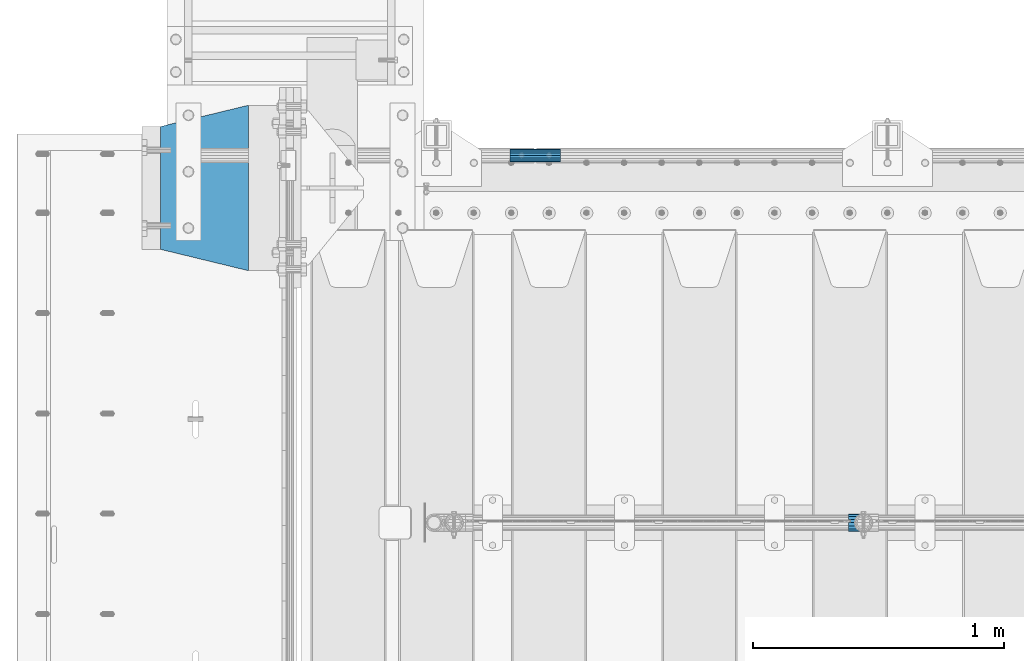
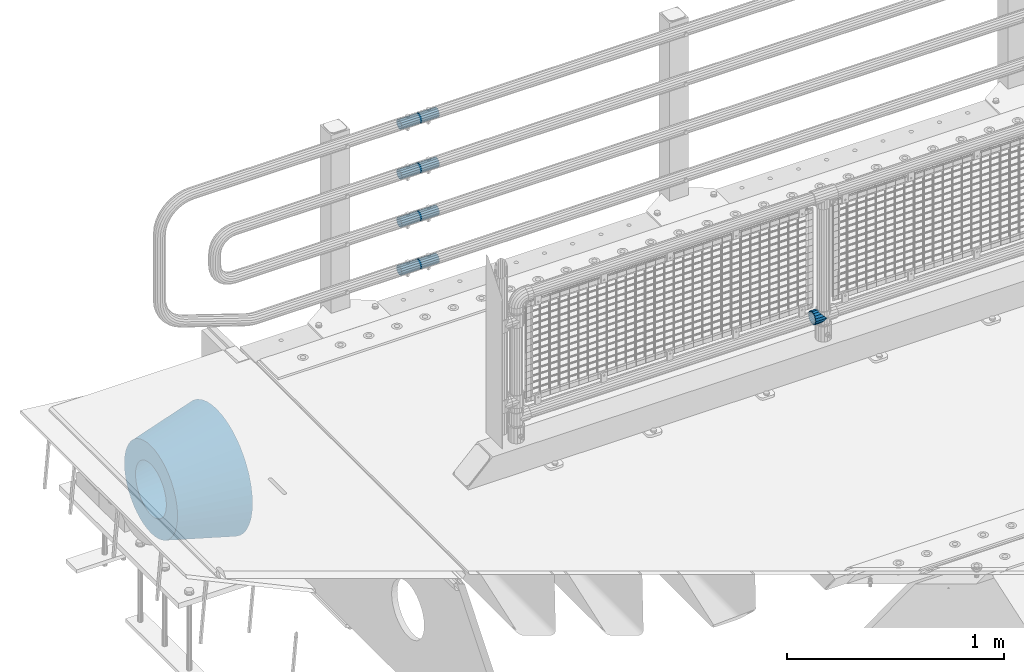
# One storey, part 162 of 270: 6 beams.
"""IFC2X3 building model written with IfcOpenShell, lengths in millimetres."""

from ifc_helpers import new_model, si_unit, frame, origin_with_axes, place, context, subcontext, project, spatial, faceted_brep, material, type_object, element, save


model = new_model("IFC2X3")

# Units and contexts
model_context = context("Model", 3, precision=1e-05, world=origin_with_axes())
body_context = subcontext(model_context, "Body", "Model", "MODEL_VIEW")
ifc_project = project(units=[si_unit("LENGTHUNIT", "METRE", prefix="MILLI"), si_unit("AREAUNIT", "SQUARE_METRE"), si_unit("VOLUMEUNIT", "CUBIC_METRE"), si_unit("MASSUNIT", "GRAM", prefix="KILO"), si_unit("TIMEUNIT", "SECOND"), si_unit("PLANEANGLEUNIT", "RADIAN"), si_unit("SOLIDANGLEUNIT", "STERADIAN"), si_unit("THERMODYNAMICTEMPERATUREUNIT", "DEGREE_CELSIUS"), si_unit("LUMINOUSINTENSITYUNIT", "LUMEN")], contexts=[model_context])

# Site, building, storey
site_placement = place(None, origin_with_axes())
site = spatial("IfcSite", under=ifc_project, at=site_placement, CompositionType="ELEMENT")
building_placement = place(site_placement, origin_with_axes())
building = spatial("IfcBuilding", under=site, at=building_placement, Name="Standard", CompositionType="ELEMENT")
storey_placement = place(building_placement, origin_with_axes())
storey = spatial("IfcBuildingStorey", under=building, at=storey_placement, Name="Undefined", CompositionType="ELEMENT", Elevation=0.0)

# Beams
ifc_material_1 = material(Name="Misc_Undefined")
beam_type_1 = type_object("IfcBeamType", PredefinedType="NOTDEFINED")
beam_1_placement = place(storey_placement, frame((2193.85, -16335.5, 298.17), z_axis=(0.0, 1.0, 0.0), x_axis=(1.0, 0.0, 0.0)))
element("IfcBeam", 1, at=beam_1_placement, inside=storey, type_object=beam_type_1, material=ifc_material_1, context=body_context, shape_type="Brep", body=[
    faceted_brep([(60.1499999999978, 0.0, -35.1499999999996), (46.698677352364, 13.4513226476329, -32.4743655677721), (46.698677352364, -13.4513226476329, -32.4743655677721), (33.0273231408937, 21.4606908090117, 21.4606908090118), (27.6756344322275, 26.8123795176776, 13.4513226476338), (27.6756344322275, 32.4743655677717, 13.4513226476338), (35.2951966412911, 24.8548033587072, 24.8548033587067), (35.2951966412911, 16.3810424080045, 24.8548033587067), (27.310256188277, 28.0397438117175, 11.6144421722802), (24.9999999999964, 30.35, 0.0), (24.9999999999964, 35.15, 0.0), (27.6756344322275, 26.8123795176775, -13.4513226476338), (27.6756344322275, 32.4743655677717, -13.4513226476338), (27.310256188277, 28.0397438117175, -11.6144421722802), (35.2951966412911, 16.3810424080045, -24.8548033587067), (35.2951966412911, 24.8548033587072, -24.8548033587067), (33.0273231408937, 21.4606908090117, -21.4606908090118), (40.0617968770166, 11.6144421722805, -28.0397438117179), (43.519339601633, 0.0, -30.3500000000004), (40.0617968770166, -11.6144421722805, -28.0397438117179), (35.2951966412911, -16.3810424080045, -24.8548033587067), (35.2951966412911, -24.8548033587072, -24.8548033587067), (33.0273231408937, -21.4606908090117, -21.4606908090118), (27.6756344322275, -26.8123795176776, -13.4513226476338), (27.6756344322275, -32.4743655677717, -13.4513226476338), (27.310256188277, -28.0397438117175, -11.6144421722802), (24.9999999999964, -30.35, 0.0), (24.9999999999964, -35.15, 0.0), (27.310256188277, -28.0397438117175, 11.6144421722802), (27.6756344322275, -26.8123795176775, 13.4513226476338), (27.6756344322275, -32.4743655677717, 13.4513226476338), (33.0273231408937, -21.4606908090117, 21.4606908090118), (35.2951966412911, -16.3810424080078, 24.8548033587067), (35.2951966412911, -24.8548033587072, 24.8548033587067), (60.1499999999978, 0.0, 35.1499999999996), (46.698677352364, -13.4513226476329, 32.4743655677721), (46.698677352364, 13.4513226476329, 32.4743655677721), (40.061796877013, -11.6144421722805, 28.0397438117179), (43.5193396016293, 0.0, 30.3500000000004), (40.061796877013, 11.6144421722805, 28.0397438117179), (0.0, -32.4743655677721, -13.4513226476338), (0.0, -24.8548033587067, -24.8548033587067), (0.0, -13.4513226476338, -32.4743655677703), (0.0, 0.0, -35.1499999999996), (0.0, 13.4513226476338, -32.4743655677703), (0.0, 24.8548033587067, -24.8548033587067), (0.0, 32.4743655677721, -13.4513226476338), (0.0, 35.1499999999996, 0.0), (0.0, 32.4743655677721, 13.4513226476338), (0.0, 24.8548033587067, 24.8548033587067), (0.0, 13.4513226476338, 32.4743655677703), (0.0, 0.0, 35.1499999999996), (0.0, -32.4743655677721, 13.4513226476338), (0.0, -35.1499999999996, 0.0), (0.0, -24.8548033587067, 24.8548033587067), (0.0, -13.4513226476338, 32.4743655677703), (0.0, -28.0397438117179, -11.614442172282), (0.0, -21.4606908090118, -21.46069080901), (0.0, -11.6144421722802, -28.0397438117179), (0.0, 0.0, -30.3499999999985), (0.0, 11.6144421722802, -28.0397438117179), (0.0, 21.4606908090118, -21.46069080901), (0.0, 28.0397438117179, -11.614442172282), (0.0, 30.3500000000004, 0.0), (0.0, 28.0397438117179, 11.614442172282), (0.0, 21.4606908090118, 21.46069080901), (0.0, 11.6144421722802, 28.0397438117179), (0.0, 0.0, 30.3499999999985), (0.0, -11.6144421722802, 28.0397438117179), (0.0, -21.4606908090118, 21.46069080901), (0.0, -28.0397438117179, 11.614442172282), (0.0, -30.3500000000004, 0.0)], [[[0, 1, 2]], [[3, 4, 5, 6, 7]], [[8, 9, 10, 5, 4]], [[11, 12, 10, 9, 13]], [[14, 15, 12, 11, 16]], [[2, 1, 15, 14, 17, 18, 19, 20, 21]], [[21, 20, 22, 23, 24]], [[24, 23, 25, 26, 27]], [[27, 26, 28, 29, 30]], [[30, 29, 31, 32, 33]], [[34, 35, 36]], [[33, 32, 37, 38, 39, 7, 6, 36, 35]], [[40, 41, 21, 24]], [[41, 42, 2, 21]], [[42, 43, 0, 2]], [[43, 44, 1, 0]], [[44, 45, 15, 1]], [[45, 46, 12, 15]], [[46, 47, 10, 12]], [[47, 48, 5, 10]], [[48, 49, 6, 5]], [[49, 50, 36, 6]], [[50, 51, 34, 36]], [[52, 53, 27, 30]], [[54, 52, 30, 33]], [[55, 54, 33, 35]], [[51, 55, 35, 34]], [[53, 40, 24, 27]], [[52, 54, 55, 51, 50, 49, 48, 47, 46, 45, 44, 43, 42, 41, 40, 53], [56, 57, 58, 59, 60, 61, 62, 63, 64, 65, 66, 67, 68, 69, 70, 71]], [[68, 67, 38, 37]], [[31, 69, 68, 37, 32]], [[28, 70, 69, 31, 29]], [[71, 70, 28, 26]], [[56, 71, 26, 25]], [[57, 56, 25, 23, 22]], [[58, 57, 22, 20, 19]], [[59, 58, 19, 18]], [[60, 59, 18, 17]], [[16, 61, 60, 17, 14]], [[13, 62, 61, 16, 11]], [[63, 62, 13, 9]], [[64, 63, 9, 8]], [[65, 64, 8, 4, 3]], [[66, 65, 3, 7, 39]], [[67, 66, 39, 38]]]),
])
ifc_material_2 = material()
beam_type_2 = type_object("IfcBeamType", PredefinedType="NOTDEFINED")
beam_2_placement = place(storey_placement, frame((844.997502999948, -14870.1499999996, 149.849999999726), z_axis=(0.0, 0.0, 1.0), x_axis=(1.0, 0.0, 0.0)))
element("IfcBeam", 2, at=beam_2_placement, inside=storey, type_object=beam_type_2, material=ifc_material_2, context=body_context, shape_type="Brep", body=[
    faceted_brep([(0.0, -21.8999999999996, 0.0), (0.0, -20.232961761998, 8.38076716879547), (200.0, -20.232961761998, 8.38076716879547), (200.0, -21.8999999999996, 0.0), (0.0, -15.4856385079856, 15.4856385079854), (200.0, -15.4856385079856, 15.4856385079854), (0.0, -8.3807671687955, 20.2329617619972), (200.0, -8.3807671687955, 20.2329617619972), (0.0, 0.0, 21.9), (200.0, 0.0, 21.9), (0.0, 8.3807671687955, 20.2329617619972), (200.0, 8.3807671687955, 20.2329617619972), (0.0, 15.4856385079856, 15.4856385079854), (200.0, 15.4856385079856, 15.4856385079854), (0.0, 20.232961761998, 8.38076716879547), (200.0, 20.232961761998, 8.38076716879547), (0.0, 21.8999999999996, 0.0), (200.0, 21.8999999999996, 0.0), (0.0, 20.232961761998, -8.38076716879547), (200.0, 20.232961761998, -8.38076716879547), (0.0, 15.4856385079856, -15.4856385079854), (200.0, 15.4856385079856, -15.4856385079854), (0.0, 8.3807671687955, -20.2329617619972), (200.0, 8.3807671687955, -20.2329617619972), (0.0, 0.0, -21.9), (200.0, 0.0, -21.9), (0.0, -8.3807671687955, -20.2329617619972), (200.0, -8.3807671687955, -20.2329617619972), (0.0, -15.4856385079856, -15.4856385079854), (200.0, -15.4856385079856, -15.4856385079854), (0.0, -20.232961761998, -8.38076716879547), (200.0, -20.232961761998, -8.38076716879547), (0.0, -25.5, 0.0), (0.0, -23.5589280790373, -9.7584275253098), (200.0, -23.5589280790373, -9.7584275253098), (200.0, -25.5, 0.0), (0.0, -18.0312229202573, -18.031222920257), (200.0, -18.0312229202573, -18.031222920257), (0.0, -9.75842752531025, -23.5589280790378), (200.0, -9.75842752531025, -23.5589280790378), (0.0, 0.0, -25.5), (200.0, 0.0, -25.5), (0.0, 9.75842752531025, -23.5589280790378), (200.0, 9.75842752531025, -23.5589280790378), (0.0, 18.0312229202573, -18.031222920257), (200.0, 18.0312229202573, -18.031222920257), (0.0, 23.5589280790373, -9.7584275253098), (200.0, 23.5589280790373, -9.7584275253098), (0.0, 25.5, 0.0), (200.0, 25.5, 0.0), (0.0, 23.5589280790373, 9.7584275253098), (200.0, 23.5589280790373, 9.7584275253098), (0.0, 18.0312229202573, 18.031222920257), (200.0, 18.0312229202573, 18.031222920257), (0.0, 9.75842752531025, 23.5589280790378), (200.0, 9.75842752531025, 23.5589280790378), (0.0, 0.0, 25.5), (200.0, 0.0, 25.5), (0.0, -9.75842752531025, 23.5589280790378), (200.0, -9.75842752531025, 23.5589280790378), (0.0, -18.0312229202573, 18.031222920257), (200.0, -18.0312229202573, 18.031222920257), (0.0, -23.5589280790373, 9.7584275253098), (200.0, -23.5589280790373, 9.7584275253098)], [[[0, 1, 2, 3]], [[1, 4, 5, 2]], [[4, 6, 7, 5]], [[6, 8, 9, 7]], [[8, 10, 11, 9]], [[10, 12, 13, 11]], [[12, 14, 15, 13]], [[14, 16, 17, 15]], [[16, 18, 19, 17]], [[18, 20, 21, 19]], [[20, 22, 23, 21]], [[22, 24, 25, 23]], [[24, 26, 27, 25]], [[26, 28, 29, 27]], [[28, 30, 31, 29]], [[30, 0, 3, 31]], [[32, 33, 34, 35]], [[33, 36, 37, 34]], [[36, 38, 39, 37]], [[38, 40, 41, 39]], [[40, 42, 43, 41]], [[42, 44, 45, 43]], [[44, 46, 47, 45]], [[46, 48, 49, 47]], [[48, 50, 51, 49]], [[50, 52, 53, 51]], [[52, 54, 55, 53]], [[54, 56, 57, 55]], [[56, 58, 59, 57]], [[58, 60, 61, 59]], [[60, 62, 63, 61]], [[62, 32, 35, 63]], [[37, 39, 41, 43, 45, 47, 49, 51, 53, 55, 57, 59, 61, 63, 35, 34], [5, 7, 9, 11, 13, 15, 17, 19, 21, 23, 25, 27, 29, 31, 3, 2]], [[62, 60, 58, 56, 54, 52, 50, 48, 46, 44, 42, 40, 38, 36, 33, 32], [30, 28, 26, 24, 22, 20, 18, 16, 14, 12, 10, 8, 6, 4, 1, 0]]]),
])
beam_3_placement = place(storey_placement, frame((844.997502999948, -14870.1499999996, 420.149999999725), z_axis=(0.0, 0.0, 1.0), x_axis=(1.0, 0.0, 0.0)))
element("IfcBeam", 3, at=beam_3_placement, inside=storey, type_object=beam_type_2, material=ifc_material_2, context=body_context, shape_type="Brep", body=[
    faceted_brep([(0.0, -21.8999999999996, 0.0), (0.0, -20.232961761998, 8.38076716879547), (200.0, -20.232961761998, 8.38076716879547), (200.0, -21.8999999999996, 0.0), (0.0, -15.4856385079856, 15.4856385079854), (200.0, -15.4856385079856, 15.4856385079854), (0.0, -8.3807671687955, 20.2329617619972), (200.0, -8.3807671687955, 20.2329617619972), (0.0, 0.0, 21.9), (200.0, 0.0, 21.9), (0.0, 8.3807671687955, 20.2329617619972), (200.0, 8.3807671687955, 20.2329617619972), (0.0, 15.4856385079856, 15.4856385079854), (200.0, 15.4856385079856, 15.4856385079854), (0.0, 20.232961761998, 8.38076716879547), (200.0, 20.232961761998, 8.38076716879547), (0.0, 21.8999999999996, 0.0), (200.0, 21.8999999999996, 0.0), (0.0, 20.232961761998, -8.38076716879547), (200.0, 20.232961761998, -8.38076716879547), (0.0, 15.4856385079856, -15.4856385079854), (200.0, 15.4856385079856, -15.4856385079854), (0.0, 8.3807671687955, -20.2329617619972), (200.0, 8.3807671687955, -20.2329617619972), (0.0, 0.0, -21.9), (200.0, 0.0, -21.9), (0.0, -8.3807671687955, -20.2329617619972), (200.0, -8.3807671687955, -20.2329617619972), (0.0, -15.4856385079856, -15.4856385079854), (200.0, -15.4856385079856, -15.4856385079854), (0.0, -20.232961761998, -8.38076716879547), (200.0, -20.232961761998, -8.38076716879547), (0.0, -25.5, 0.0), (0.0, -23.5589280790373, -9.7584275253098), (200.0, -23.5589280790373, -9.7584275253098), (200.0, -25.5, 0.0), (0.0, -18.0312229202573, -18.031222920257), (200.0, -18.0312229202573, -18.031222920257), (0.0, -9.75842752531025, -23.5589280790378), (200.0, -9.75842752531025, -23.5589280790378), (0.0, 0.0, -25.5), (200.0, 0.0, -25.5), (0.0, 9.75842752531025, -23.5589280790378), (200.0, 9.75842752531025, -23.5589280790378), (0.0, 18.0312229202573, -18.031222920257), (200.0, 18.0312229202573, -18.031222920257), (0.0, 23.5589280790373, -9.7584275253098), (200.0, 23.5589280790373, -9.7584275253098), (0.0, 25.5, 0.0), (200.0, 25.5, 0.0), (0.0, 23.5589280790373, 9.7584275253098), (200.0, 23.5589280790373, 9.7584275253098), (0.0, 18.0312229202573, 18.031222920257), (200.0, 18.0312229202573, 18.031222920257), (0.0, 9.75842752531025, 23.5589280790378), (200.0, 9.75842752531025, 23.5589280790378), (0.0, 0.0, 25.5), (200.0, 0.0, 25.5), (0.0, -9.75842752531025, 23.5589280790378), (200.0, -9.75842752531025, 23.5589280790378), (0.0, -18.0312229202573, 18.031222920257), (200.0, -18.0312229202573, 18.031222920257), (0.0, -23.5589280790373, 9.7584275253098), (200.0, -23.5589280790373, 9.7584275253098)], [[[0, 1, 2, 3]], [[1, 4, 5, 2]], [[4, 6, 7, 5]], [[6, 8, 9, 7]], [[8, 10, 11, 9]], [[10, 12, 13, 11]], [[12, 14, 15, 13]], [[14, 16, 17, 15]], [[16, 18, 19, 17]], [[18, 20, 21, 19]], [[20, 22, 23, 21]], [[22, 24, 25, 23]], [[24, 26, 27, 25]], [[26, 28, 29, 27]], [[28, 30, 31, 29]], [[30, 0, 3, 31]], [[32, 33, 34, 35]], [[33, 36, 37, 34]], [[36, 38, 39, 37]], [[38, 40, 41, 39]], [[40, 42, 43, 41]], [[42, 44, 45, 43]], [[44, 46, 47, 45]], [[46, 48, 49, 47]], [[48, 50, 51, 49]], [[50, 52, 53, 51]], [[52, 54, 55, 53]], [[54, 56, 57, 55]], [[56, 58, 59, 57]], [[58, 60, 61, 59]], [[60, 62, 63, 61]], [[62, 32, 35, 63]], [[37, 39, 41, 43, 45, 47, 49, 51, 53, 55, 57, 59, 61, 63, 35, 34], [5, 7, 9, 11, 13, 15, 17, 19, 21, 23, 25, 27, 29, 31, 3, 2]], [[62, 60, 58, 56, 54, 52, 50, 48, 46, 44, 42, 40, 38, 36, 33, 32], [30, 28, 26, 24, 22, 20, 18, 16, 14, 12, 10, 8, 6, 4, 1, 0]]]),
])
beam_4_placement = place(storey_placement, frame((844.997502999948, -14870.1499999996, 969.849999999726), z_axis=(0.0, 0.0, 1.0), x_axis=(1.0, 0.0, 0.0)))
element("IfcBeam", 4, at=beam_4_placement, inside=storey, type_object=beam_type_2, material=ifc_material_2, context=body_context, shape_type="Brep", body=[
    faceted_brep([(0.0, -21.8999999999996, 0.0), (0.0, -20.232961761998, 8.38076716879547), (200.0, -20.232961761998, 8.38076716879547), (200.0, -21.8999999999996, 0.0), (0.0, -15.4856385079856, 15.4856385079854), (200.0, -15.4856385079856, 15.4856385079854), (0.0, -8.3807671687955, 20.2329617619972), (200.0, -8.3807671687955, 20.2329617619972), (0.0, 0.0, 21.9), (200.0, 0.0, 21.9), (0.0, 8.3807671687955, 20.2329617619972), (200.0, 8.3807671687955, 20.2329617619972), (0.0, 15.4856385079856, 15.4856385079854), (200.0, 15.4856385079856, 15.4856385079854), (0.0, 20.232961761998, 8.38076716879547), (200.0, 20.232961761998, 8.38076716879547), (0.0, 21.8999999999996, 0.0), (200.0, 21.8999999999996, 0.0), (0.0, 20.232961761998, -8.38076716879547), (200.0, 20.232961761998, -8.38076716879547), (0.0, 15.4856385079856, -15.4856385079854), (200.0, 15.4856385079856, -15.4856385079854), (0.0, 8.3807671687955, -20.2329617619972), (200.0, 8.3807671687955, -20.2329617619972), (0.0, 0.0, -21.9), (200.0, 0.0, -21.9), (0.0, -8.3807671687955, -20.2329617619972), (200.0, -8.3807671687955, -20.2329617619972), (0.0, -15.4856385079856, -15.4856385079854), (200.0, -15.4856385079856, -15.4856385079854), (0.0, -20.232961761998, -8.38076716879547), (200.0, -20.232961761998, -8.38076716879547), (0.0, -25.5, 0.0), (0.0, -23.5589280790373, -9.7584275253098), (200.0, -23.5589280790373, -9.7584275253098), (200.0, -25.5, 0.0), (0.0, -18.0312229202573, -18.031222920257), (200.0, -18.0312229202573, -18.031222920257), (0.0, -9.75842752531025, -23.5589280790378), (200.0, -9.75842752531025, -23.5589280790378), (0.0, 0.0, -25.5), (200.0, 0.0, -25.5), (0.0, 9.75842752531025, -23.5589280790378), (200.0, 9.75842752531025, -23.5589280790378), (0.0, 18.0312229202573, -18.031222920257), (200.0, 18.0312229202573, -18.031222920257), (0.0, 23.5589280790373, -9.7584275253098), (200.0, 23.5589280790373, -9.7584275253098), (0.0, 25.5, 0.0), (200.0, 25.5, 0.0), (0.0, 23.5589280790373, 9.7584275253098), (200.0, 23.5589280790373, 9.7584275253098), (0.0, 18.0312229202573, 18.031222920257), (200.0, 18.0312229202573, 18.031222920257), (0.0, 9.75842752531025, 23.5589280790378), (200.0, 9.75842752531025, 23.5589280790378), (0.0, 0.0, 25.5), (200.0, 0.0, 25.5), (0.0, -9.75842752531025, 23.5589280790378), (200.0, -9.75842752531025, 23.5589280790378), (0.0, -18.0312229202573, 18.031222920257), (200.0, -18.0312229202573, 18.031222920257), (0.0, -23.5589280790373, 9.7584275253098), (200.0, -23.5589280790373, 9.7584275253098)], [[[0, 1, 2, 3]], [[1, 4, 5, 2]], [[4, 6, 7, 5]], [[6, 8, 9, 7]], [[8, 10, 11, 9]], [[10, 12, 13, 11]], [[12, 14, 15, 13]], [[14, 16, 17, 15]], [[16, 18, 19, 17]], [[18, 20, 21, 19]], [[20, 22, 23, 21]], [[22, 24, 25, 23]], [[24, 26, 27, 25]], [[26, 28, 29, 27]], [[28, 30, 31, 29]], [[30, 0, 3, 31]], [[32, 33, 34, 35]], [[33, 36, 37, 34]], [[36, 38, 39, 37]], [[38, 40, 41, 39]], [[40, 42, 43, 41]], [[42, 44, 45, 43]], [[44, 46, 47, 45]], [[46, 48, 49, 47]], [[48, 50, 51, 49]], [[50, 52, 53, 51]], [[52, 54, 55, 53]], [[54, 56, 57, 55]], [[56, 58, 59, 57]], [[58, 60, 61, 59]], [[60, 62, 63, 61]], [[62, 32, 35, 63]], [[37, 39, 41, 43, 45, 47, 49, 51, 53, 55, 57, 59, 61, 63, 35, 34], [5, 7, 9, 11, 13, 15, 17, 19, 21, 23, 25, 27, 29, 31, 3, 2]], [[62, 60, 58, 56, 54, 52, 50, 48, 46, 44, 42, 40, 38, 36, 33, 32], [30, 28, 26, 24, 22, 20, 18, 16, 14, 12, 10, 8, 6, 4, 1, 0]]]),
])
beam_5_placement = place(storey_placement, frame((844.997502999948, -14870.1499999996, 689.849999999726), z_axis=(0.0, 0.0, 1.0), x_axis=(1.0, 0.0, 0.0)))
element("IfcBeam", 5, at=beam_5_placement, inside=storey, type_object=beam_type_2, material=ifc_material_2, context=body_context, shape_type="Brep", body=[
    faceted_brep([(0.0, -21.8999999999996, 0.0), (0.0, -20.232961761998, 8.38076716879547), (200.0, -20.232961761998, 8.38076716879547), (200.0, -21.8999999999996, 0.0), (0.0, -15.4856385079856, 15.4856385079854), (200.0, -15.4856385079856, 15.4856385079854), (0.0, -8.3807671687955, 20.2329617619972), (200.0, -8.3807671687955, 20.2329617619972), (0.0, 0.0, 21.9), (200.0, 0.0, 21.9), (0.0, 8.3807671687955, 20.2329617619972), (200.0, 8.3807671687955, 20.2329617619972), (0.0, 15.4856385079856, 15.4856385079854), (200.0, 15.4856385079856, 15.4856385079854), (0.0, 20.232961761998, 8.38076716879547), (200.0, 20.232961761998, 8.38076716879547), (0.0, 21.8999999999996, 0.0), (200.0, 21.8999999999996, 0.0), (0.0, 20.232961761998, -8.38076716879547), (200.0, 20.232961761998, -8.38076716879547), (0.0, 15.4856385079856, -15.4856385079854), (200.0, 15.4856385079856, -15.4856385079854), (0.0, 8.3807671687955, -20.2329617619972), (200.0, 8.3807671687955, -20.2329617619972), (0.0, 0.0, -21.9), (200.0, 0.0, -21.9), (0.0, -8.3807671687955, -20.2329617619972), (200.0, -8.3807671687955, -20.2329617619972), (0.0, -15.4856385079856, -15.4856385079854), (200.0, -15.4856385079856, -15.4856385079854), (0.0, -20.232961761998, -8.38076716879547), (200.0, -20.232961761998, -8.38076716879547), (0.0, -25.5, 0.0), (0.0, -23.5589280790373, -9.7584275253098), (200.0, -23.5589280790373, -9.7584275253098), (200.0, -25.5, 0.0), (0.0, -18.0312229202573, -18.031222920257), (200.0, -18.0312229202573, -18.031222920257), (0.0, -9.75842752531025, -23.5589280790378), (200.0, -9.75842752531025, -23.5589280790378), (0.0, 0.0, -25.5), (200.0, 0.0, -25.5), (0.0, 9.75842752531025, -23.5589280790378), (200.0, 9.75842752531025, -23.5589280790378), (0.0, 18.0312229202573, -18.031222920257), (200.0, 18.0312229202573, -18.031222920257), (0.0, 23.5589280790373, -9.7584275253098), (200.0, 23.5589280790373, -9.7584275253098), (0.0, 25.5, 0.0), (200.0, 25.5, 0.0), (0.0, 23.5589280790373, 9.7584275253098), (200.0, 23.5589280790373, 9.7584275253098), (0.0, 18.0312229202573, 18.031222920257), (200.0, 18.0312229202573, 18.031222920257), (0.0, 9.75842752531025, 23.5589280790378), (200.0, 9.75842752531025, 23.5589280790378), (0.0, 0.0, 25.5), (200.0, 0.0, 25.5), (0.0, -9.75842752531025, 23.5589280790378), (200.0, -9.75842752531025, 23.5589280790378), (0.0, -18.0312229202573, 18.031222920257), (200.0, -18.0312229202573, 18.031222920257), (0.0, -23.5589280790373, 9.7584275253098), (200.0, -23.5589280790373, 9.7584275253098)], [[[0, 1, 2, 3]], [[1, 4, 5, 2]], [[4, 6, 7, 5]], [[6, 8, 9, 7]], [[8, 10, 11, 9]], [[10, 12, 13, 11]], [[12, 14, 15, 13]], [[14, 16, 17, 15]], [[16, 18, 19, 17]], [[18, 20, 21, 19]], [[20, 22, 23, 21]], [[22, 24, 25, 23]], [[24, 26, 27, 25]], [[26, 28, 29, 27]], [[28, 30, 31, 29]], [[30, 0, 3, 31]], [[32, 33, 34, 35]], [[33, 36, 37, 34]], [[36, 38, 39, 37]], [[38, 40, 41, 39]], [[40, 42, 43, 41]], [[42, 44, 45, 43]], [[44, 46, 47, 45]], [[46, 48, 49, 47]], [[48, 50, 51, 49]], [[50, 52, 53, 51]], [[52, 54, 55, 53]], [[54, 56, 57, 55]], [[56, 58, 59, 57]], [[58, 60, 61, 59]], [[60, 62, 63, 61]], [[62, 32, 35, 63]], [[37, 39, 41, 43, 45, 47, 49, 51, 53, 55, 57, 59, 61, 63, 35, 34], [5, 7, 9, 11, 13, 15, 17, 19, 21, 23, 25, 27, 29, 31, 3, 2]], [[62, 60, 58, 56, 54, 52, 50, 48, 46, 44, 42, 40, 38, 36, 33, 32], [30, 28, 26, 24, 22, 20, 18, 16, 14, 12, 10, 8, 6, 4, 1, 0]]]),
])
ifc_material_3 = material(Name="SCN-500-E2")
beam_type_3 = type_object("IfcBeamType", PredefinedType="NOTDEFINED")
beam_6_placement = place(storey_placement, frame((-199.999999999991, -15000.0, -515.0), z_axis=(0.0, 0.0, 1.0), x_axis=(-1.0, 0.0, 0.0)))
element("IfcBeam", 6, at=beam_6_placement, inside=storey, type_object=beam_type_3, material=ifc_material_3, context=body_context, shape_type="Brep", body=[
    faceted_brep([(0.0, -330.0, 0.0), (0.0, -326.641075820708, -46.9638966301842), (350.0, -242.506253260828, -34.8671353769549), (350.0, -245.0, 0.0), (0.0, -316.632681292784, -92.9717437576718), (350.0, -235.075778535553, -69.0244764261503), (0.0, -300.178558466991, -137.086954290623), (350.0, -222.859838861858, -101.776678185462), (0.0, -277.613665834289, -178.411469760347), (350.0, -206.10711554364, -132.457000276621), (0.0, -249.397359536906, -216.104042201944), (350.0, -185.158645716794, -160.440879816595), (0.0, -216.104042201943, -249.397359536905), (350.0, -160.440879816595, -185.158645716793), (0.0, -178.411469760347, -277.61366583429), (350.0, -132.457000276621, -206.107115543639), (0.0, -137.086954290622, -300.178558466991), (350.0, -101.776678185463, -222.859838861857), (0.0, -92.971743757671, -316.632681292784), (350.0, -69.0244764261497, -235.075778535552), (0.0, -46.9638966301845, -326.641075820708), (350.0, -34.867135376955, -242.506253260829), (0.0, 0.0, -330.0), (350.0, 0.0, -245.0), (0.0, 46.9638966301845, -326.641075820708), (350.0, 34.867135376955, -242.506253260829), (0.0, 92.971743757671, -316.632681292784), (350.0, 69.0244764261497, -235.075778535552), (0.0, 137.086954290622, -300.178558466991), (350.0, 101.776678185463, -222.859838861857), (0.0, 178.411469760347, -277.61366583429), (350.0, 132.457000276621, -206.107115543639), (0.0, 216.104042201943, -249.397359536905), (350.0, 160.440879816595, -185.158645716793), (0.0, 249.397359536906, -216.104042201944), (350.0, 185.158645716794, -160.440879816595), (0.0, 277.613665834289, -178.411469760347), (350.0, 206.10711554364, -132.457000276621), (0.0, 300.178558466991, -137.086954290623), (350.0, 222.859838861858, -101.776678185462), (0.0, 316.632681292784, -92.9717437576717), (350.0, 235.075778535553, -69.0244764261502), (0.0, 326.641075820708, -46.9638966301841), (350.0, 242.506253260828, -34.8671353769548), (0.0, 330.0, 0.0), (350.0, 245.0, 0.0), (0.0, 326.641075820708, 46.9638966301841), (350.0, 242.506253260828, 34.8671353769549), (0.0, 316.632681292784, 92.9717437576718), (350.0, 235.075778535553, 69.0244764261503), (0.0, 300.178558466991, 137.086954290622), (350.0, 222.859838861858, 101.776678185462), (0.0, 277.613665834289, 178.411469760347), (350.0, 206.10711554364, 132.457000276621), (0.0, 249.397359536904, 216.104042201944), (350.0, 185.158645716794, 160.440879816595), (0.0, 216.104042201943, 249.397359536905), (350.0, 160.440879816595, 185.158645716793), (0.0, 178.411469760347, 277.61366583429), (350.0, 132.457000276621, 206.107115543639), (0.0, 137.086954290622, 300.178558466991), (350.0, 101.776678185463, 222.859838861857), (0.0, 92.971743757671, 316.632681292784), (350.0, 69.0244764261497, 235.075778535552), (0.0, 46.9638966301845, 326.641075820708), (350.0, 34.867135376955, 242.506253260829), (0.0, 0.0, 330.0), (350.0, 0.0, 245.0), (0.0, -46.9638966301845, 326.641075820708), (350.0, -34.867135376955, 242.506253260829), (0.0, -92.971743757671, 316.632681292784), (350.0, -69.0244764261497, 235.075778535552), (0.0, -137.086954290622, 300.178558466991), (350.0, -101.776678185463, 222.859838861857), (0.0, -178.411469760347, 277.61366583429), (350.0, -132.457000276621, 206.107115543639), (0.0, -216.104042201943, 249.397359536905), (350.0, -160.440879816595, 185.158645716793), (0.0, -249.397359536906, 216.104042201944), (350.0, -185.158645716794, 160.440879816595), (0.0, -277.613665834289, 178.411469760347), (350.0, -206.10711554364, 132.457000276621), (0.0, -300.178558466991, 137.086954290623), (350.0, -222.859838861858, 101.776678185462), (0.0, -316.632681292784, 92.9717437576718), (350.0, -235.075778535553, 69.0244764261503), (0.0, -326.641075820708, 46.9638966301841), (350.0, -242.506253260828, 34.8671353769549), (0.0, -227.093265923131, 0.0), (0.0, -224.781783917484, 32.3187414128026), (350.0, -140.646961357605, 20.2219801595734), (350.0, -142.093265923131, 0.0), (0.0, -217.894393008413, 63.9795664499945), (350.0, -136.337490251181, 40.032299118473), (0.0, -206.571300613232, 94.3379520160985), (350.0, -129.252581008099, 59.0276759109381), (0.0, -191.043012240005, 122.775888927343), (350.0, -119.536461949354, 76.8214194436173), (0.0, -171.625639060125, 148.714462796454), (350.0, -107.386925240013, 93.0513004111044), (0.0, -148.714462796454, 171.625639060125), (350.0, -93.0513004111053, 107.386925240013), (0.0, -122.775888927343, 191.043012240005), (350.0, -76.8214194436168, 119.536461949355), (0.0, -94.3379520160979, 206.571300613232), (350.0, -59.0276759109383, 129.252581008098), (0.0, -63.9795664499943, 217.894393008413), (350.0, -40.032299118473, 136.337490251181), (0.0, -32.3187414128024, 224.781783917484), (350.0, -20.2219801595729, 140.646961357605), (0.0, 0.0, 227.093265923131), (350.0, 0.0, 142.093265923131), (0.0, 32.3187414128024, 224.781783917484), (350.0, 20.2219801595729, 140.646961357605), (0.0, 63.9795664499943, 217.894393008413), (350.0, 40.032299118473, 136.337490251181), (0.0, 94.3379520160979, 206.571300613232), (350.0, 59.0276759109383, 129.252581008098), (0.0, 122.775888927343, 191.043012240005), (350.0, 76.8214194436168, 119.536461949355), (0.0, 148.714462796454, 171.625639060125), (350.0, 93.0513004111053, 107.386925240013), (0.0, 171.625639060125, 148.714462796454), (350.0, 107.386925240013, 93.0513004111044), (0.0, 191.043012240005, 122.775888927343), (350.0, 119.536461949354, 76.8214194436174), (0.0, 206.571300613232, 94.3379520160985), (350.0, 129.252581008099, 59.0276759109382), (0.0, 217.894393008413, 63.9795664499945), (350.0, 136.337490251181, 40.032299118473), (0.0, 224.781783917484, 32.3187414128025), (350.0, 140.646961357605, 20.2219801595733), (0.0, 227.093265923131, 0.0), (350.0, 142.093265923131, 0.0), (0.0, 224.781783917484, -32.3187414128026), (350.0, 140.646961357605, -20.2219801595734), (0.0, 217.894393008413, -63.9795664499945), (350.0, 136.337490251181, -40.032299118473), (0.0, 206.571300613232, -94.3379520160985), (350.0, 129.252581008099, -59.0276759109381), (0.0, 191.043012240005, -122.775888927343), (350.0, 119.536461949354, -76.8214194436174), (0.0, 171.625639060125, -148.714462796454), (350.0, 107.386925240013, -93.0513004111044), (0.0, 148.714462796454, -171.625639060125), (350.0, 93.0513004111035, -107.386925240013), (0.0, 122.775888927343, -191.043012240005), (350.0, 76.8214194436168, -119.536461949355), (0.0, 94.3379520160979, -206.571300613232), (350.0, 59.0276759109383, -129.252581008098), (0.0, 63.9795664499943, -217.894393008413), (350.0, 40.032299118473, -136.337490251181), (0.0, 32.3187414128024, -224.781783917484), (350.0, 20.2219801595729, -140.646961357605), (0.0, 0.0, -227.093265923131), (350.0, 0.0, -142.093265923131), (0.0, -32.3187414128024, -224.781783917484), (350.0, -20.2219801595729, -140.646961357605), (0.0, -63.9795664499943, -217.894393008413), (350.0, -40.032299118473, -136.337490251181), (0.0, -94.3379520160979, -206.571300613232), (350.0, -59.0276759109383, -129.252581008098), (0.0, -122.775888927343, -191.043012240005), (350.0, -76.8214194436168, -119.536461949355), (0.0, -148.714462796454, -171.625639060125), (350.0, -93.0513004111035, -107.386925240013), (0.0, -171.625639060125, -148.714462796454), (350.0, -107.386925240013, -93.0513004111044), (0.0, -191.043012240005, -122.775888927343), (350.0, -119.536461949354, -76.8214194436174), (0.0, -206.571300613232, -94.3379520160985), (350.0, -129.252581008099, -59.0276759109381), (0.0, -217.894393008413, -63.9795664499945), (350.0, -136.337490251181, -40.032299118473), (0.0, -224.781783917484, -32.3187414128026), (350.0, -140.646961357605, -20.2219801595734)], [[[0, 1, 2, 3]], [[1, 4, 5, 2]], [[4, 6, 7, 5]], [[6, 8, 9, 7]], [[8, 10, 11, 9]], [[10, 12, 13, 11]], [[12, 14, 15, 13]], [[14, 16, 17, 15]], [[16, 18, 19, 17]], [[18, 20, 21, 19]], [[20, 22, 23, 21]], [[22, 24, 25, 23]], [[24, 26, 27, 25]], [[26, 28, 29, 27]], [[28, 30, 31, 29]], [[30, 32, 33, 31]], [[32, 34, 35, 33]], [[34, 36, 37, 35]], [[36, 38, 39, 37]], [[38, 40, 41, 39]], [[40, 42, 43, 41]], [[42, 44, 45, 43]], [[44, 46, 47, 45]], [[46, 48, 49, 47]], [[48, 50, 51, 49]], [[50, 52, 53, 51]], [[52, 54, 55, 53]], [[54, 56, 57, 55]], [[56, 58, 59, 57]], [[58, 60, 61, 59]], [[60, 62, 63, 61]], [[62, 64, 65, 63]], [[64, 66, 67, 65]], [[66, 68, 69, 67]], [[68, 70, 71, 69]], [[70, 72, 73, 71]], [[72, 74, 75, 73]], [[74, 76, 77, 75]], [[76, 78, 79, 77]], [[78, 80, 81, 79]], [[80, 82, 83, 81]], [[82, 84, 85, 83]], [[84, 86, 87, 85]], [[86, 0, 3, 87]], [[88, 89, 90, 91]], [[89, 92, 93, 90]], [[92, 94, 95, 93]], [[94, 96, 97, 95]], [[96, 98, 99, 97]], [[98, 100, 101, 99]], [[100, 102, 103, 101]], [[102, 104, 105, 103]], [[104, 106, 107, 105]], [[106, 108, 109, 107]], [[108, 110, 111, 109]], [[110, 112, 113, 111]], [[112, 114, 115, 113]], [[114, 116, 117, 115]], [[116, 118, 119, 117]], [[118, 120, 121, 119]], [[120, 122, 123, 121]], [[122, 124, 125, 123]], [[124, 126, 127, 125]], [[126, 128, 129, 127]], [[128, 130, 131, 129]], [[130, 132, 133, 131]], [[132, 134, 135, 133]], [[134, 136, 137, 135]], [[136, 138, 139, 137]], [[138, 140, 141, 139]], [[140, 142, 143, 141]], [[142, 144, 145, 143]], [[144, 146, 147, 145]], [[146, 148, 149, 147]], [[148, 150, 151, 149]], [[150, 152, 153, 151]], [[152, 154, 155, 153]], [[154, 156, 157, 155]], [[156, 158, 159, 157]], [[158, 160, 161, 159]], [[160, 162, 163, 161]], [[162, 164, 165, 163]], [[164, 166, 167, 165]], [[166, 168, 169, 167]], [[168, 170, 171, 169]], [[170, 172, 173, 171]], [[172, 174, 175, 173]], [[174, 88, 91, 175]], [[5, 7, 9, 11, 13, 15, 17, 19, 21, 23, 25, 27, 29, 31, 33, 35, 37, 39, 41, 43, 45, 47, 49, 51, 53, 55, 57, 59, 61, 63, 65, 67, 69, 71, 73, 75, 77, 79, 81, 83, 85, 87, 3, 2], [93, 95, 97, 99, 101, 103, 105, 107, 109, 111, 113, 115, 117, 119, 121, 123, 125, 127, 129, 131, 133, 135, 137, 139, 141, 143, 145, 147, 149, 151, 153, 155, 157, 159, 161, 163, 165, 167, 169, 171, 173, 175, 91, 90]], [[86, 84, 82, 80, 78, 76, 74, 72, 70, 68, 66, 64, 62, 60, 58, 56, 54, 52, 50, 48, 46, 44, 42, 40, 38, 36, 34, 32, 30, 28, 26, 24, 22, 20, 18, 16, 14, 12, 10, 8, 6, 4, 1, 0], [174, 172, 170, 168, 166, 164, 162, 160, 158, 156, 154, 152, 150, 148, 146, 144, 142, 140, 138, 136, 134, 132, 130, 128, 126, 124, 122, 120, 118, 116, 114, 112, 110, 108, 106, 104, 102, 100, 98, 96, 94, 92, 89, 88]]]),
])

save(model, "model.ifc")
